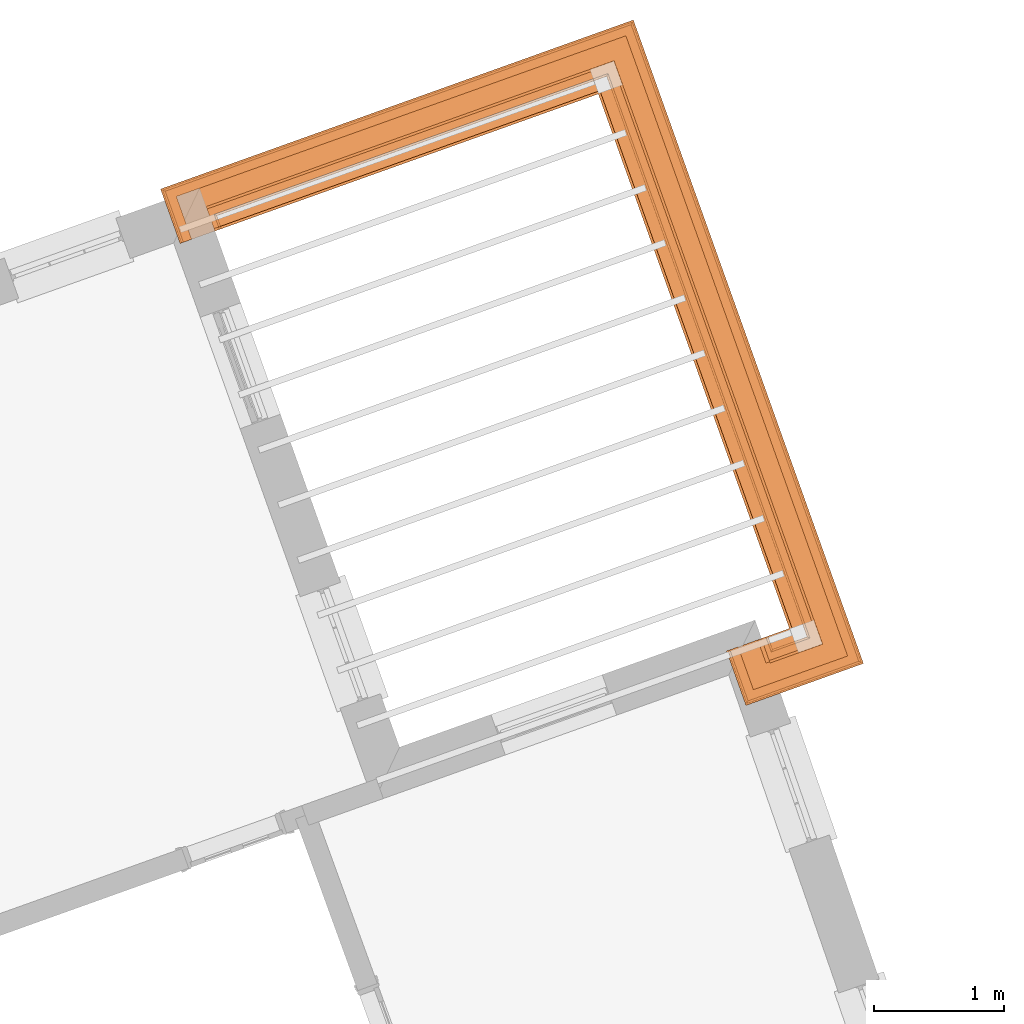
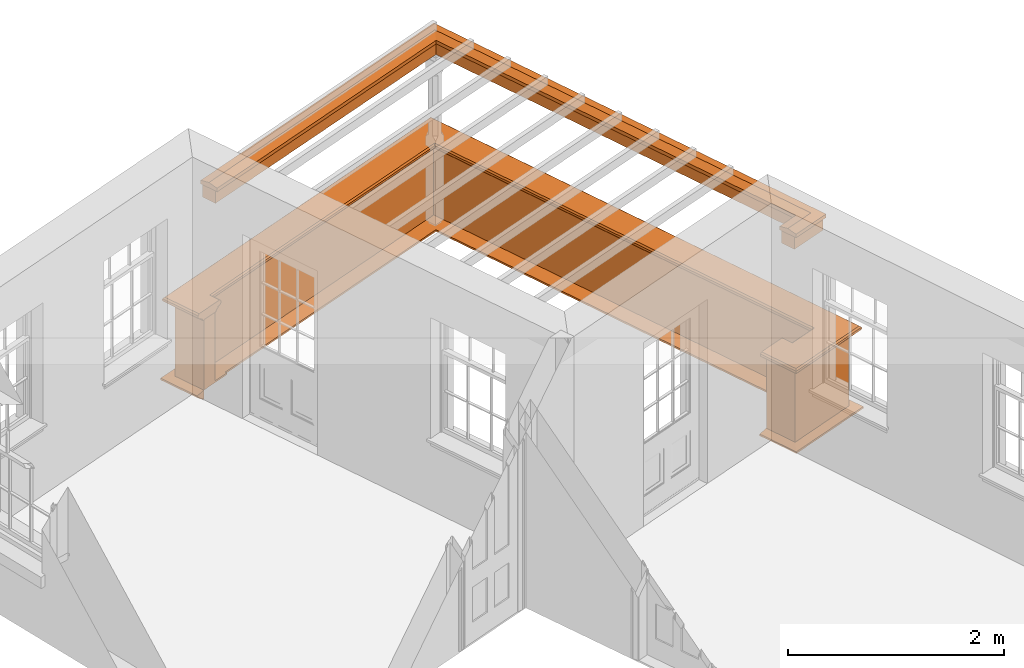
# One storey, part 11 of 12: 5 proxies.
"""IFC2X3 building model written with IfcOpenShell, lengths in metres."""

from ifc_helpers import new_model, entity, si_unit, frame, origin, place, context, subcontext, project, spatial, element, save


model = new_model("IFC2X3")

# Units and contexts
model_context = context("Model", 3, world=origin())
body_context = subcontext(model_context, "Body", "Model", "MODEL_VIEW")
ifc_project = project(units=[si_unit("PLANEANGLEUNIT", "RADIAN"), si_unit("MASSUNIT", "GRAM", prefix="KILO"), si_unit("FORCEUNIT", "NEWTON", prefix="KILO"), si_unit("LENGTHUNIT", "METRE")], contexts=[model_context])

# Site, building, storey
site_placement = place(None, origin())
site = spatial("IfcSite", under=ifc_project, at=site_placement, CompositionType="ELEMENT")
building_placement = place(None, origin())
building = spatial("IfcBuilding", under=site, at=building_placement, Name="Building plot-12", CompositionType="ELEMENT")
storey_placement = place(None, frame((0.0, 0.0, 6.45)))
storey = spatial("IfcBuildingStorey", under=building, at=storey_placement, Name="Floor 1", CompositionType="ELEMENT", Elevation=6.45)

# Proxies
proxy_1_placement = place(storey_placement, origin())
axis2_placement3_d_1 = entity("IfcAxis2Placement3D", entity("IfcCartesianPoint", [0.0, 0.0, 0.0]))
element("IfcBuildingElementProxy", 1, at=proxy_1_placement, inside=storey, Name="parapet", CompositionType="ELEMENT", context=body_context, shape_type="SweptSolid", held_by="IfcProductRepresentation", body=[
    entity("IfcSurfaceCurveSweptAreaSolid", entity("IfcArbitraryClosedProfileDef", "AREA", None, entity("IfcPolyline", [entity("IfcCartesianPoint", [0.0, 0.25]), entity("IfcCartesianPoint", [0.795, 0.25]), entity("IfcCartesianPoint", [0.795, 0.09]), entity("IfcCartesianPoint", [0.02, 0.09]), entity("IfcCartesianPoint", [0.02, -0.08]), entity("IfcCartesianPoint", [0.0, -0.08]), entity("IfcCartesianPoint", [0.0, 0.25])])), axis2_placement3_d_1, entity("IfcPolyline", [entity("IfcCartesianPoint", [60.9298261091698, 41.1030022238442]), entity("IfcCartesianPoint", [60.9634955363529, 41.008840821597]), entity("IfcCartesianPoint", [61.2173610753454, 41.0996158852157]), entity("IfcCartesianPoint", [59.6801169280114, 45.3987405398164]), entity("IfcCartesianPoint", [56.6939907797768, 44.3309871450266]), entity("IfcCartesianPoint", [56.72766020696, 44.2368257427794])]), 0.0, 1.0, entity("IfcPlane", axis2_placement3_d_1)),
])
proxy_2_placement = place(storey_placement, origin())
axis2_placement3_d_2 = entity("IfcAxis2Placement3D", entity("IfcCartesianPoint", [0.0, 0.0, 0.0]))
element("IfcBuildingElementProxy", 2, at=proxy_2_placement, inside=storey, Name="parapet", CompositionType="ELEMENT", context=body_context, shape_type="SweptSolid", held_by="IfcProductRepresentation", body=[
    entity("IfcSurfaceCurveSweptAreaSolid", entity("IfcArbitraryClosedProfileDef", "AREA", None, entity("IfcPolyline", [entity("IfcCartesianPoint", [0.795, 0.265]), entity("IfcCartesianPoint", [0.807, 0.268]), entity("IfcCartesianPoint", [0.816, 0.274]), entity("IfcCartesianPoint", [0.822, 0.283]), entity("IfcCartesianPoint", [0.825, 0.295]), entity("IfcCartesianPoint", [0.84, 0.295]), entity("IfcCartesianPoint", [0.84, 0.305]), entity("IfcCartesianPoint", [0.842, 0.317]), entity("IfcCartesianPoint", [0.849, 0.326]), entity("IfcCartesianPoint", [0.858, 0.333]), entity("IfcCartesianPoint", [0.87, 0.335]), entity("IfcCartesianPoint", [0.882, 0.333]), entity("IfcCartesianPoint", [0.891, 0.326]), entity("IfcCartesianPoint", [0.898, 0.317]), entity("IfcCartesianPoint", [0.9, 0.305]), entity("IfcCartesianPoint", [0.9, 0.035]), entity("IfcCartesianPoint", [0.898, 0.023]), entity("IfcCartesianPoint", [0.891, 0.014]), entity("IfcCartesianPoint", [0.882, 0.007]), entity("IfcCartesianPoint", [0.87, 0.005]), entity("IfcCartesianPoint", [0.858, 0.007]), entity("IfcCartesianPoint", [0.849, 0.014]), entity("IfcCartesianPoint", [0.842, 0.023]), entity("IfcCartesianPoint", [0.84, 0.035]), entity("IfcCartesianPoint", [0.84, 0.045]), entity("IfcCartesianPoint", [0.825, 0.045]), entity("IfcCartesianPoint", [0.822, 0.057]), entity("IfcCartesianPoint", [0.816, 0.066]), entity("IfcCartesianPoint", [0.807, 0.072]), entity("IfcCartesianPoint", [0.795, 0.075]), entity("IfcCartesianPoint", [0.795, 0.265])])), axis2_placement3_d_2, entity("IfcPolyline", [entity("IfcCartesianPoint", [60.9298261091698, 41.1030022238442]), entity("IfcCartesianPoint", [60.9634955363529, 41.008840821597]), entity("IfcCartesianPoint", [61.2173610753454, 41.0996158852157]), entity("IfcCartesianPoint", [59.6801169280114, 45.3987405398164]), entity("IfcCartesianPoint", [56.6939907797768, 44.3309871450266]), entity("IfcCartesianPoint", [56.72766020696, 44.2368257427794])]), 0.0, 1.0, entity("IfcPlane", axis2_placement3_d_2)),
])
proxy_3_placement = place(storey_placement, origin())
axis2_placement3_d_3 = entity("IfcAxis2Placement3D", entity("IfcCartesianPoint", [0.0, 0.0, 0.0]))
element("IfcBuildingElementProxy", 3, at=proxy_3_placement, inside=storey, Name="parapet", CompositionType="ELEMENT", context=body_context, shape_type="SweptSolid", held_by="IfcProductRepresentation", body=[
    entity("IfcSurfaceCurveSweptAreaSolid", entity("IfcArbitraryClosedProfileDef", "AREA", None, entity("IfcPolyline", [entity("IfcCartesianPoint", [-0.1, 0.25]), entity("IfcCartesianPoint", [-0.1, 0.265]), entity("IfcCartesianPoint", [-0.085, 0.265]), entity("IfcCartesianPoint", [-0.084, 0.278]), entity("IfcCartesianPoint", [-0.081, 0.289]), entity("IfcCartesianPoint", [-0.074, 0.301]), entity("IfcCartesianPoint", [-0.065, 0.309]), entity("IfcCartesianPoint", [-0.055, 0.315]), entity("IfcCartesianPoint", [-0.044, 0.324]), entity("IfcCartesianPoint", [-0.038, 0.334]), entity("IfcCartesianPoint", [-0.035, 0.345]), entity("IfcCartesianPoint", [-0.015, 0.345]), entity("IfcCartesianPoint", [0.0, 0.25]), entity("IfcCartesianPoint", [-0.1, 0.25])])), axis2_placement3_d_3, entity("IfcPolyline", [entity("IfcCartesianPoint", [60.9298261091698, 41.1030022238442]), entity("IfcCartesianPoint", [60.9634955363529, 41.008840821597]), entity("IfcCartesianPoint", [61.2173610753454, 41.0996158852157]), entity("IfcCartesianPoint", [59.6801169280114, 45.3987405398164]), entity("IfcCartesianPoint", [56.6939907797768, 44.3309871450266]), entity("IfcCartesianPoint", [56.72766020696, 44.2368257427794])]), 0.0, 1.0, entity("IfcPlane", axis2_placement3_d_3)),
])
proxy_4_placement = place(storey_placement, frame((0.0, 0.0, 2.7)))
axis2_placement3_d_4 = entity("IfcAxis2Placement3D", entity("IfcCartesianPoint", [0.0, 0.0, 0.0]))
element("IfcBuildingElementProxy", 4, at=proxy_4_placement, inside=storey, Name="pergola beam", CompositionType="ELEMENT", context=body_context, shape_type="SweptSolid", held_by="IfcProductRepresentation", body=[
    entity("IfcSurfaceCurveSweptAreaSolid", entity("IfcArbitraryClosedProfileDef", "AREA", None, entity("IfcPolyline", [entity("IfcCartesianPoint", [-0.7, -0.08]), entity("IfcCartesianPoint", [-0.7, 0.08]), entity("IfcCartesianPoint", [-0.56, 0.08]), entity("IfcCartesianPoint", [-0.56, -0.08]), entity("IfcCartesianPoint", [-0.7, -0.08])])), axis2_placement3_d_4, entity("IfcPolyline", [entity("IfcCartesianPoint", [60.9069986950046, 40.9886391652871]), entity("IfcCartesianPoint", [61.2173610753454, 41.0996158852157]), entity("IfcCartesianPoint", [59.6801169280114, 45.3987405398164]), entity("IfcCartesianPoint", [56.6374939384285, 44.3107854887167])]), 0.0, 1.0, entity("IfcPlane", axis2_placement3_d_4)),
])
proxy_5_placement = place(storey_placement, frame((0.0, 0.0, 2.7)))
axis2_placement3_d_5 = entity("IfcAxis2Placement3D", entity("IfcCartesianPoint", [0.0, 0.0, 0.0]))
element("IfcBuildingElementProxy", 5, at=proxy_5_placement, inside=storey, Name="pergola beam", CompositionType="ELEMENT", context=body_context, shape_type="SweptSolid", held_by="IfcProductRepresentation", body=[
    entity("IfcSurfaceCurveSweptAreaSolid", entity("IfcArbitraryClosedProfileDef", "AREA", None, entity("IfcPolyline", [entity("IfcCartesianPoint", [-0.5, 0.0]), entity("IfcCartesianPoint", [-0.52, -0.1]), entity("IfcCartesianPoint", [-0.56, -0.1]), entity("IfcCartesianPoint", [-0.56, 0.1]), entity("IfcCartesianPoint", [-0.52, 0.1]), entity("IfcCartesianPoint", [-0.5, 0.0])])), axis2_placement3_d_5, entity("IfcPolyline", [entity("IfcCartesianPoint", [60.9069986950046, 40.9886391652871]), entity("IfcCartesianPoint", [61.2173610753454, 41.0996158852157]), entity("IfcCartesianPoint", [59.6801169280114, 45.3987405398164]), entity("IfcCartesianPoint", [56.6374939384285, 44.3107854887167])]), 0.0, 1.0, entity("IfcPlane", axis2_placement3_d_5)),
])

save(model, "model.ifc")
